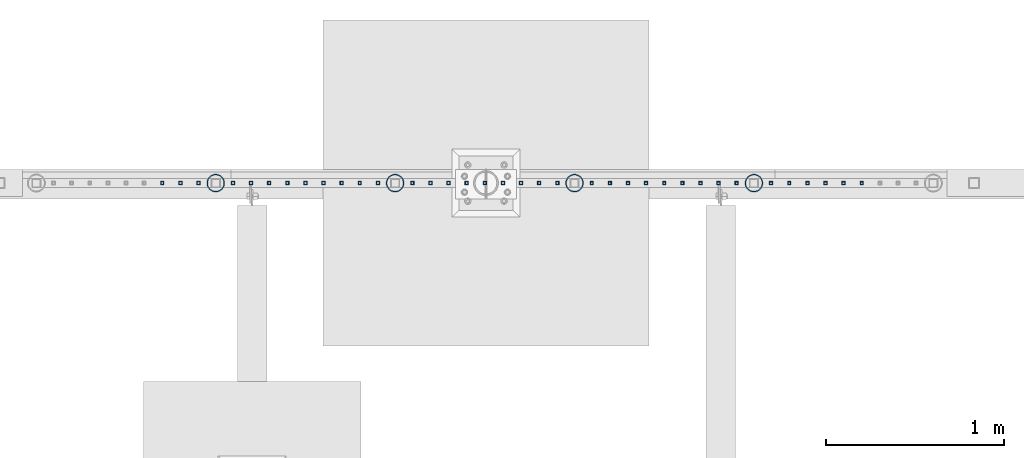
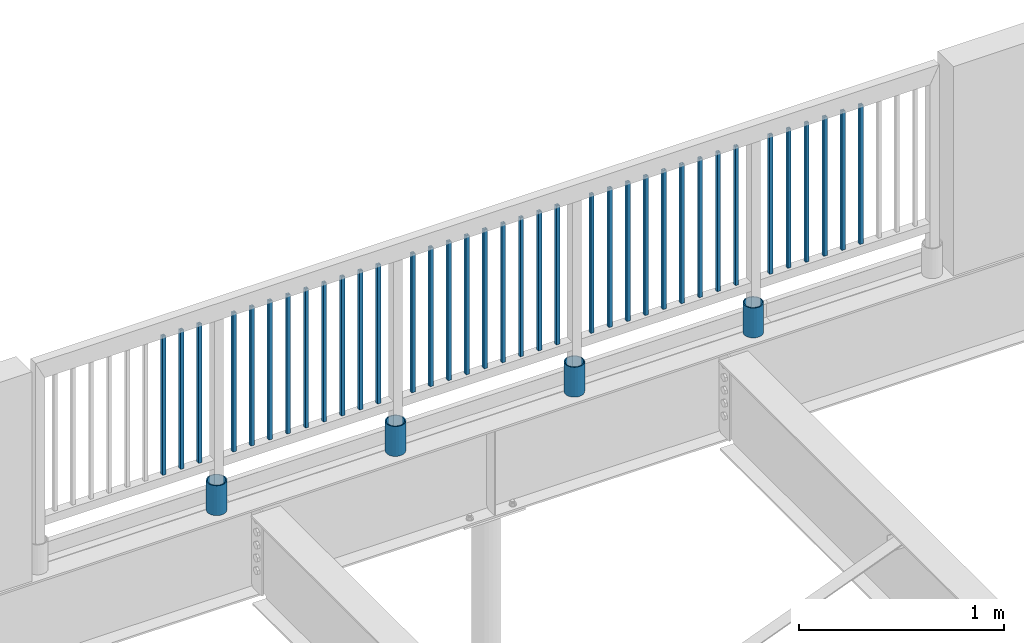
# One storey, part 234 of 975: 40 columns.
"""IFC2X3 building model written with IfcOpenShell, lengths in millimetres."""

from ifc_helpers import new_model, si_unit, frame, origin_with_axes, place, context, subcontext, project, spatial, faceted_brep, material, type_object, element, save


model = new_model("IFC2X3")

# Units and contexts
model_context = context("Model", 3, precision=1e-05, world=origin_with_axes())
body_context = subcontext(model_context, "Body", "Model", "MODEL_VIEW")
ifc_project = project(units=[si_unit("LENGTHUNIT", "METRE", prefix="MILLI"), si_unit("AREAUNIT", "SQUARE_METRE"), si_unit("VOLUMEUNIT", "CUBIC_METRE"), si_unit("MASSUNIT", "GRAM", prefix="KILO"), si_unit("TIMEUNIT", "SECOND"), si_unit("PLANEANGLEUNIT", "RADIAN"), si_unit("SOLIDANGLEUNIT", "STERADIAN"), si_unit("THERMODYNAMICTEMPERATUREUNIT", "DEGREE_CELSIUS"), si_unit("LUMINOUSINTENSITYUNIT", "LUMEN")], contexts=[model_context])

# Site, building, storey
site_placement = place(None, origin_with_axes())
site = spatial("IfcSite", under=ifc_project, at=site_placement, CompositionType="ELEMENT")
building_placement = place(site_placement, origin_with_axes())
building = spatial("IfcBuilding", under=site, at=building_placement, Name="Undefined", CompositionType="ELEMENT")
storey_placement = place(building_placement, origin_with_axes())
storey = spatial("IfcBuildingStorey", under=building, at=storey_placement, Name="Undefined", CompositionType="ELEMENT", Elevation=0.0)

# Columns
ifc_material_1 = material()
column_type_1 = type_object("IfcColumnType", Name="HSS3/4X3/4X.120_TUBES", PredefinedType="NOTDEFINED")
for number, where, z_axis, x_axis, name in (
    (1, (11647.8074787112, 29962.1756613159, 4254.49117560355), (1.0, 0.0, 0.0), (0.0, 0.0, 1.0), "PICKET"),
    (2, (11546.2074787112, 29962.1756613159, 4254.49117560355), (1.0, 0.0, 0.0), (0.0, 0.0, 1.0), "PICKET"),
    (3, (11444.6074787112, 29962.1756613159, 4254.49117560355), (1.0, 0.0, 0.0), (0.0, 0.0, 1.0), "PICKET"),
    (4, (11343.0074787112, 29962.1756613159, 4254.49117560355), (1.0, 0.0, 0.0), (0.0, 0.0, 1.0), "PICKET"),
    (5, (11241.4074787112, 29962.1756613159, 4254.49117560355), (1.0, 0.0, 0.0), (0.0, 0.0, 1.0), "PICKET"),
    (6, (11139.8074787112, 29962.1756613159, 4254.49117560355), (1.0, 0.0, 0.0), (0.0, 0.0, 1.0), "PICKET"),
    (7, (10946.7670968707, 29962.1851834192, 4254.49124442222), (1.0, 0.0, 0.0), (0.0, 0.0, 1.0), "PICKET"),
    (8, (10845.1670968707, 29962.1851834192, 4254.49124442222), (1.0, 0.0, 0.0), (0.0, 0.0, 1.0), "PICKET"),
    (9, (10743.5670968707, 29962.1851834192, 4254.49124442222), (1.0, 0.0, 0.0), (0.0, 0.0, 1.0), "PICKET"),
    (10, (10641.9670968707, 29962.1851834192, 4254.49124442222), (1.0, 0.0, 0.0), (0.0, 0.0, 1.0), "PICKET"),
    (11, (10540.3670968707, 29962.1851834192, 4254.49124442222), (1.0, 0.0, 0.0), (0.0, 0.0, 1.0), "PICKET"),
    (12, (10438.7670968707, 29962.1851834192, 4254.49124442222), (1.0, 0.0, 0.0), (0.0, 0.0, 1.0), "PICKET"),
    (13, (10337.1670968707, 29962.1851834192, 4254.49124442222), (1.0, 0.0, 0.0), (0.0, 0.0, 1.0), "PICKET"),
    (14, (10235.5670968707, 29962.1851834192, 4254.49124442222), (1.0, 0.0, 0.0), (0.0, 0.0, 1.0), "PICKET"),
    (15, (10133.9670968707, 29962.1851834192, 4254.49124442222), (1.0, 0.0, 0.0), (0.0, 0.0, 1.0), "PICKET"),
    (16, (9940.92734308254, 29962.3497637264, 4254.4913822527), (1.0, 0.0, 0.0), (0.0, 0.0, 1.0), "PICKET"),
    (17, (9839.32734308254, 29962.3497637264, 4254.4913822527), (1.0, 0.0, 0.0), (0.0, 0.0, 1.0), "PICKET"),
    (18, (9737.72734308254, 29962.3497637264, 4254.4913822527), (1.0, 0.0, 0.0), (0.0, 0.0, 1.0), "PICKET"),
    (19, (9636.12734308254, 29962.3497637264, 4254.4913822527), (1.0, 0.0, 0.0), (0.0, 0.0, 1.0), "PICKET"),
    (20, (9534.52734308254, 29962.3497637264, 4254.4913822527), (1.0, 0.0, 0.0), (0.0, 0.0, 1.0), "PICKET"),
    (21, (9432.92734308254, 29962.3497637264, 4254.4913822527), (1.0, 0.0, 0.0), (0.0, 0.0, 1.0), "PICKET"),
    (22, (9331.32734308254, 29962.3497637264, 4254.4913822527), (1.0, 0.0, 0.0), (0.0, 0.0, 1.0), "PICKET"),
    (23, (9229.72734308254, 29962.3497637264, 4254.4913822527), (1.0, 0.0, 0.0), (0.0, 0.0, 1.0), "PICKET"),
    (24, (9128.12734308254, 29962.3497637264, 4254.4913822527), (1.0, 0.0, 0.0), (0.0, 0.0, 1.0), "PICKET"),
    (25, (8935.08757637993, 29962.3592857994, 4254.49152008318), (1.0, 0.0, 0.0), (0.0, 0.0, 1.0), "PICKET"),
    (26, (8833.48757637993, 29962.3592857994, 4254.49152008318), (1.0, 0.0, 0.0), (0.0, 0.0, 1.0), "PICKET"),
    (27, (8731.88757637993, 29962.3592857994, 4254.49152008318), (1.0, 0.0, 0.0), (0.0, 0.0, 1.0), "PICKET"),
    (28, (8630.28757637993, 29962.3592857994, 4254.49152008318), (1.0, 0.0, 0.0), (0.0, 0.0, 1.0), "PICKET"),
    (29, (8528.68757637993, 29962.3592857994, 4254.49152008318), (1.0, 0.0, 0.0), (0.0, 0.0, 1.0), "PICKET"),
    (30, (8427.08757637993, 29962.3592857994, 4254.49152008318), (1.0, 0.0, 0.0), (0.0, 0.0, 1.0), "PICKET"),
    (31, (8325.48757637993, 29962.3592857994, 4254.49152008318), (1.0, 0.0, 0.0), (0.0, 0.0, 1.0), "PICKET"),
    (32, (8223.88757637994, 29962.3592857994, 4254.49152008318), (1.0, 0.0, 0.0), (0.0, 0.0, 1.0), "PICKET"),
    (33, (8122.28757637993, 29962.3592857994, 4254.49152008318), (1.0, 0.0, 0.0), (0.0, 0.0, 1.0), "PICKET"),
    (34, (7929.24783012341, 29962.3688078713, 4254.49165791356), (1.0, 0.0, 0.0), (0.0, 0.0, 1.0), "PICKET"),
    (35, (7827.6478301234, 29962.3688078713, 4254.49165791356), (1.0, 0.0, 0.0), (0.0, 0.0, 1.0), "PICKET"),
    (36, (7726.0478301234, 29962.3688078713, 4254.49165791356), (1.0, 0.0, 0.0), (0.0, 0.0, 1.0), "PICKET"),
):
    element("IfcColumn", number, at=place(storey_placement, frame(where, z_axis=z_axis, x_axis=x_axis)), inside=storey, type_object=column_type_1, material=ifc_material_1, Name=name, ObjectType="HSS3/4X3/4X.120_TUBES", context=body_context, shape_type="Brep", body=[
        faceted_brep([(0.0, 6.34999999998763, -6.34999999998763), (0.0, -6.35000000000582, -6.34999999998763), (825.49997943247, -6.35000000000582, -6.34999999998763), (825.49997943247, 6.34999999998763, -6.34999999998763), (0.0, -6.34999999998763, 6.34999999998763), (825.49997943247, -6.34999999998763, 6.34999999998763), (0.0, 6.35000000000946, 6.34999999998763), (825.49997943247, 6.35000000000946, 6.34999999998763), (0.0, 9.52499999997963, -9.52499999997963), (0.0, 9.52500000000873, 9.5249999999869), (825.49997943247, 9.52500000000873, 9.5249999999869), (825.49997943247, 9.52499999997963, -9.52499999997963), (0.0, -9.52499999997963, 9.52499999998327), (825.49997943247, -9.52499999997963, 9.52499999998327), (0.0, -9.52500000000873, -9.5249999999869), (825.49997943247, -9.52500000000873, -9.5249999999869)], [[[0, 1, 2, 3]], [[1, 4, 5, 2]], [[4, 6, 7, 5]], [[6, 0, 3, 7]], [[8, 9, 10, 11]], [[9, 12, 13, 10]], [[12, 14, 15, 13]], [[14, 8, 11, 15]], [[13, 15, 11, 10], [5, 7, 3, 2]], [[14, 12, 9, 8], [6, 4, 1, 0]]]),
    ])
ifc_material_2 = material(Name="STEEL/A53")
column_type_2 = type_object("IfcColumnType", Name="PIPE3-1/2STD", PredefinedType="NOTDEFINED")
column_1_placement = place(storey_placement, frame((11043.2862680762, 29962.0937719637, 3937.0), z_axis=(-0.707106781186601, 0.707106781186494, 2.36468622460961e-14), x_axis=(0.0, 0.0, 1.0)))
element("IfcColumn", 37, at=column_1_placement, inside=storey, type_object=column_type_2, material=ifc_material_2, ObjectType="PIPE3-1/2STD", context=body_context, shape_type="Brep", body=[
    faceted_brep([(0.0, -45.0595999999932, 1.45519152283669e-11), (0.0, -42.8542262016344, 13.924182159768), (177.8, -42.8542262016344, 13.924182159768), (177.8, -45.0595999999932, 1.45519152283669e-11), (0.0, -36.45398215971, 26.4853683542424), (177.8, -36.45398215971, 26.4853683542424), (0.0, -26.4853683541623, 36.45398215979), (177.8, -26.4853683541623, 36.45398215979), (0.0, -13.9241821596988, 42.8542262017108), (177.8, -13.9241821596988, 42.8542262017108), (0.0, 3.63797880709171e-11, 45.0596000000514), (177.8, 3.63797880709171e-11, 45.0596000000514), (0.0, 13.9241821597716, 42.8542262017036), (177.8, 13.9241821597716, 42.8542262017036), (0.0, 26.4853683542242, 36.4539821597718), (177.8, 26.4853683542242, 36.4539821597718), (0.0, 36.4539821597537, 26.4853683542206), (177.8, 36.4539821597537, 26.4853683542206), (0.0, 42.8542262016563, 13.9241821597425), (177.8, 42.8542262016563, 13.9241821597425), (0.0, 45.0595999999932, -1.09139364212751e-11), (177.8, 45.0595999999932, -1.09139364212751e-11), (0.0, 42.8542262016344, -13.9241821597643), (177.8, 42.8542262016344, -13.9241821597643), (0.0, 36.45398215971, -26.4853683542387), (177.8, 36.45398215971, -26.4853683542387), (0.0, 26.4853683541623, -36.4539821597864), (177.8, 26.4853683541623, -36.4539821597864), (0.0, 13.9241821596988, -42.8542262017072), (177.8, 13.9241821596988, -42.8542262017072), (0.0, -3.63797880709171e-11, -45.0596000000478), (177.8, -3.63797880709171e-11, -45.0596000000478), (0.0, -13.9241821597716, -42.8542262016963), (177.8, -13.9241821597716, -42.8542262016963), (0.0, -26.4853683542242, -36.4539821597682), (177.8, -26.4853683542242, -36.4539821597682), (0.0, -36.4539821597537, -26.4853683542169), (177.8, -36.4539821597537, -26.4853683542169), (0.0, -42.8542262016563, -13.9241821597352), (177.8, -42.8542262016563, -13.9241821597352), (0.0, -50.799999999992, 1.81898940354586e-11), (0.0, -48.3136710278013, -15.6980633142484), (177.8, -48.3136710278013, -15.6980633142484), (177.8, -50.799999999992, 1.81898940354586e-11), (0.0, -41.0980633142644, -29.8594908164741), (177.8, -41.0980633142644, -29.8594908164741), (0.0, -29.859490816485, -41.0980633142826), (177.8, -29.859490816485, -41.0980633142826), (0.0, -15.6980633142848, -48.313671027845), (177.8, -15.6980633142848, -48.313671027845), (0.0, -4.36557456851006e-11, -50.8000000000575), (177.8, -4.36557456851006e-11, -50.8000000000575), (0.0, 15.6980633142011, -48.3136710278523), (177.8, 15.6980633142011, -48.3136710278523), (0.0, 29.8594908164159, -41.0980633143045), (177.8, 29.8594908164159, -41.0980633143045), (0.0, 41.0980633142135, -29.8594908165032), (177.8, 41.0980633142135, -29.8594908165032), (0.0, 48.3136710277722, -15.6980633142775), (177.8, 48.3136710277722, -15.6980633142775), (0.0, 50.799999999992, -1.45519152283669e-11), (177.8, 50.799999999992, -1.45519152283669e-11), (0.0, 48.313671027794, 15.6980633142521), (177.8, 48.313671027794, 15.6980633142521), (0.0, 41.0980633142644, 29.8594908164814), (177.8, 41.0980633142644, 29.8594908164814), (0.0, 29.859490816485, 41.0980633142863), (177.8, 29.859490816485, 41.0980633142863), (0.0, 15.6980633142848, 48.3136710278486), (177.8, 15.6980633142848, 48.3136710278486), (0.0, 4.00177668780088e-11, 50.8000000000611), (177.8, 4.00177668780088e-11, 50.8000000000611), (0.0, -15.6980633142011, 48.3136710278559), (177.8, -15.6980633142011, 48.3136710278559), (0.0, -29.8594908164159, 41.0980633143081), (177.8, -29.8594908164159, 41.0980633143081), (0.0, -41.0980633142171, 29.8594908165069), (177.8, -41.0980633142171, 29.8594908165069), (0.0, -48.3136710277722, 15.6980633142812), (177.8, -48.3136710277722, 15.6980633142812)], [[[0, 1, 2, 3]], [[1, 4, 5, 2]], [[4, 6, 7, 5]], [[6, 8, 9, 7]], [[8, 10, 11, 9]], [[10, 12, 13, 11]], [[12, 14, 15, 13]], [[14, 16, 17, 15]], [[16, 18, 19, 17]], [[18, 20, 21, 19]], [[20, 22, 23, 21]], [[22, 24, 25, 23]], [[24, 26, 27, 25]], [[26, 28, 29, 27]], [[28, 30, 31, 29]], [[30, 32, 33, 31]], [[32, 34, 35, 33]], [[34, 36, 37, 35]], [[36, 38, 39, 37]], [[38, 0, 3, 39]], [[40, 41, 42, 43]], [[41, 44, 45, 42]], [[44, 46, 47, 45]], [[46, 48, 49, 47]], [[48, 50, 51, 49]], [[50, 52, 53, 51]], [[52, 54, 55, 53]], [[54, 56, 57, 55]], [[56, 58, 59, 57]], [[58, 60, 61, 59]], [[60, 62, 63, 61]], [[62, 64, 65, 63]], [[64, 66, 67, 65]], [[66, 68, 69, 67]], [[68, 70, 71, 69]], [[70, 72, 73, 71]], [[72, 74, 75, 73]], [[74, 76, 77, 75]], [[76, 78, 79, 77]], [[78, 40, 43, 79]], [[45, 47, 49, 51, 53, 55, 57, 59, 61, 63, 65, 67, 69, 71, 73, 75, 77, 79, 43, 42], [5, 7, 9, 11, 13, 15, 17, 19, 21, 23, 25, 27, 29, 31, 33, 35, 37, 39, 3, 2]], [[78, 76, 74, 72, 70, 68, 66, 64, 62, 60, 58, 56, 54, 52, 50, 48, 46, 44, 41, 40], [38, 36, 34, 32, 30, 28, 26, 24, 22, 20, 18, 16, 14, 12, 10, 8, 6, 4, 1, 0]]]),
])
column_2_placement = place(storey_placement, frame((10037.4465056714, 29962.1891578516, 3937.0), z_axis=(-0.707106781186601, 0.707106781186494, 2.36468622460961e-14), x_axis=(0.0, 0.0, 1.0)))
element("IfcColumn", 38, at=column_2_placement, inside=storey, type_object=column_type_2, material=ifc_material_2, ObjectType="PIPE3-1/2STD", context=body_context, shape_type="Brep", body=[
    faceted_brep([(0.0, -45.0595999999932, 1.45519152283669e-11), (0.0, -42.8542262016344, 13.924182159768), (177.8, -42.8542262016344, 13.924182159768), (177.8, -45.0595999999932, 1.45519152283669e-11), (0.0, -36.45398215971, 26.4853683542424), (177.8, -36.45398215971, 26.4853683542424), (0.0, -26.4853683541623, 36.45398215979), (177.8, -26.4853683541623, 36.45398215979), (0.0, -13.9241821596988, 42.8542262017108), (177.8, -13.9241821596988, 42.8542262017108), (0.0, 3.63797880709171e-11, 45.0596000000514), (177.8, 3.63797880709171e-11, 45.0596000000514), (0.0, 13.9241821597716, 42.8542262017036), (177.8, 13.9241821597716, 42.8542262017036), (0.0, 26.4853683542242, 36.4539821597718), (177.8, 26.4853683542242, 36.4539821597718), (0.0, 36.4539821597537, 26.4853683542206), (177.8, 36.4539821597537, 26.4853683542206), (0.0, 42.8542262016563, 13.9241821597425), (177.8, 42.8542262016563, 13.9241821597425), (0.0, 45.0595999999932, -1.09139364212751e-11), (177.8, 45.0595999999932, -1.09139364212751e-11), (0.0, 42.8542262016344, -13.9241821597643), (177.8, 42.8542262016344, -13.9241821597643), (0.0, 36.45398215971, -26.4853683542387), (177.8, 36.45398215971, -26.4853683542387), (0.0, 26.4853683541623, -36.4539821597864), (177.8, 26.4853683541623, -36.4539821597864), (0.0, 13.9241821596988, -42.8542262017072), (177.8, 13.9241821596988, -42.8542262017072), (0.0, -3.63797880709171e-11, -45.0596000000478), (177.8, -3.63797880709171e-11, -45.0596000000478), (0.0, -13.9241821597716, -42.8542262016963), (177.8, -13.9241821597716, -42.8542262016963), (0.0, -26.4853683542242, -36.4539821597682), (177.8, -26.4853683542242, -36.4539821597682), (0.0, -36.4539821597537, -26.4853683542169), (177.8, -36.4539821597537, -26.4853683542169), (0.0, -42.8542262016563, -13.9241821597352), (177.8, -42.8542262016563, -13.9241821597352), (0.0, -50.799999999992, 1.81898940354586e-11), (0.0, -48.3136710278013, -15.6980633142484), (177.8, -48.3136710278013, -15.6980633142484), (177.8, -50.799999999992, 1.81898940354586e-11), (0.0, -41.0980633142644, -29.8594908164741), (177.8, -41.0980633142644, -29.8594908164741), (0.0, -29.859490816485, -41.0980633142826), (177.8, -29.859490816485, -41.0980633142826), (0.0, -15.6980633142848, -48.313671027845), (177.8, -15.6980633142848, -48.313671027845), (0.0, -4.36557456851006e-11, -50.8000000000575), (177.8, -4.36557456851006e-11, -50.8000000000575), (0.0, 15.6980633142011, -48.3136710278523), (177.8, 15.6980633142011, -48.3136710278523), (0.0, 29.8594908164159, -41.0980633143045), (177.8, 29.8594908164159, -41.0980633143045), (0.0, 41.0980633142135, -29.8594908165032), (177.8, 41.0980633142135, -29.8594908165032), (0.0, 48.3136710277722, -15.6980633142775), (177.8, 48.3136710277722, -15.6980633142775), (0.0, 50.799999999992, -1.45519152283669e-11), (177.8, 50.799999999992, -1.45519152283669e-11), (0.0, 48.313671027794, 15.6980633142521), (177.8, 48.313671027794, 15.6980633142521), (0.0, 41.0980633142644, 29.8594908164814), (177.8, 41.0980633142644, 29.8594908164814), (0.0, 29.859490816485, 41.0980633142863), (177.8, 29.859490816485, 41.0980633142863), (0.0, 15.6980633142848, 48.3136710278486), (177.8, 15.6980633142848, 48.3136710278486), (0.0, 4.00177668780088e-11, 50.8000000000611), (177.8, 4.00177668780088e-11, 50.8000000000611), (0.0, -15.6980633142011, 48.3136710278559), (177.8, -15.6980633142011, 48.3136710278559), (0.0, -29.8594908164159, 41.0980633143081), (177.8, -29.8594908164159, 41.0980633143081), (0.0, -41.0980633142171, 29.8594908165069), (177.8, -41.0980633142171, 29.8594908165069), (0.0, -48.3136710277722, 15.6980633142812), (177.8, -48.3136710277722, 15.6980633142812)], [[[0, 1, 2, 3]], [[1, 4, 5, 2]], [[4, 6, 7, 5]], [[6, 8, 9, 7]], [[8, 10, 11, 9]], [[10, 12, 13, 11]], [[12, 14, 15, 13]], [[14, 16, 17, 15]], [[16, 18, 19, 17]], [[18, 20, 21, 19]], [[20, 22, 23, 21]], [[22, 24, 25, 23]], [[24, 26, 27, 25]], [[26, 28, 29, 27]], [[28, 30, 31, 29]], [[30, 32, 33, 31]], [[32, 34, 35, 33]], [[34, 36, 37, 35]], [[36, 38, 39, 37]], [[38, 0, 3, 39]], [[40, 41, 42, 43]], [[41, 44, 45, 42]], [[44, 46, 47, 45]], [[46, 48, 49, 47]], [[48, 50, 51, 49]], [[50, 52, 53, 51]], [[52, 54, 55, 53]], [[54, 56, 57, 55]], [[56, 58, 59, 57]], [[58, 60, 61, 59]], [[60, 62, 63, 61]], [[62, 64, 65, 63]], [[64, 66, 67, 65]], [[66, 68, 69, 67]], [[68, 70, 71, 69]], [[70, 72, 73, 71]], [[72, 74, 75, 73]], [[74, 76, 77, 75]], [[76, 78, 79, 77]], [[78, 40, 43, 79]], [[45, 47, 49, 51, 53, 55, 57, 59, 61, 63, 65, 67, 69, 71, 73, 75, 77, 79, 43, 42], [5, 7, 9, 11, 13, 15, 17, 19, 21, 23, 25, 27, 29, 31, 33, 35, 37, 39, 3, 2]], [[78, 76, 74, 72, 70, 68, 66, 64, 62, 60, 58, 56, 54, 52, 50, 48, 46, 44, 41, 40], [38, 36, 34, 32, 30, 28, 26, 24, 22, 20, 18, 16, 14, 12, 10, 8, 6, 4, 1, 0]]]),
])
column_3_placement = place(storey_placement, frame((9031.60674328245, 29962.2845441947, 3937.0), z_axis=(-0.707106781186601, 0.707106781186494, 2.36468622460961e-14), x_axis=(0.0, 0.0, 1.0)))
element("IfcColumn", 39, at=column_3_placement, inside=storey, type_object=column_type_2, material=ifc_material_2, ObjectType="PIPE3-1/2STD", context=body_context, shape_type="Brep", body=[
    faceted_brep([(0.0, -45.0595999999932, 1.45519152283669e-11), (0.0, -42.8542262016344, 13.924182159768), (177.8, -42.8542262016344, 13.924182159768), (177.8, -45.0595999999932, 1.45519152283669e-11), (0.0, -36.45398215971, 26.4853683542424), (177.8, -36.45398215971, 26.4853683542424), (0.0, -26.4853683541623, 36.45398215979), (177.8, -26.4853683541623, 36.45398215979), (0.0, -13.9241821596988, 42.8542262017108), (177.8, -13.9241821596988, 42.8542262017108), (0.0, 3.63797880709171e-11, 45.0596000000514), (177.8, 3.63797880709171e-11, 45.0596000000514), (0.0, 13.9241821597716, 42.8542262017036), (177.8, 13.9241821597716, 42.8542262017036), (0.0, 26.4853683542242, 36.4539821597718), (177.8, 26.4853683542242, 36.4539821597718), (0.0, 36.4539821597537, 26.4853683542206), (177.8, 36.4539821597537, 26.4853683542206), (0.0, 42.8542262016563, 13.9241821597425), (177.8, 42.8542262016563, 13.9241821597425), (0.0, 45.0595999999932, -1.09139364212751e-11), (177.8, 45.0595999999932, -1.09139364212751e-11), (0.0, 42.8542262016344, -13.9241821597643), (177.8, 42.8542262016344, -13.9241821597643), (0.0, 36.45398215971, -26.4853683542387), (177.8, 36.45398215971, -26.4853683542387), (0.0, 26.4853683541623, -36.4539821597864), (177.8, 26.4853683541623, -36.4539821597864), (0.0, 13.9241821596988, -42.8542262017072), (177.8, 13.9241821596988, -42.8542262017072), (0.0, -3.63797880709171e-11, -45.0596000000478), (177.8, -3.63797880709171e-11, -45.0596000000478), (0.0, -13.9241821597716, -42.8542262016963), (177.8, -13.9241821597716, -42.8542262016963), (0.0, -26.4853683542242, -36.4539821597682), (177.8, -26.4853683542242, -36.4539821597682), (0.0, -36.4539821597537, -26.4853683542169), (177.8, -36.4539821597537, -26.4853683542169), (0.0, -42.8542262016563, -13.9241821597352), (177.8, -42.8542262016563, -13.9241821597352), (0.0, -50.799999999992, 1.81898940354586e-11), (0.0, -48.3136710278013, -15.6980633142484), (177.8, -48.3136710278013, -15.6980633142484), (177.8, -50.799999999992, 1.81898940354586e-11), (0.0, -41.0980633142644, -29.8594908164741), (177.8, -41.0980633142644, -29.8594908164741), (0.0, -29.859490816485, -41.0980633142826), (177.8, -29.859490816485, -41.0980633142826), (0.0, -15.6980633142848, -48.313671027845), (177.8, -15.6980633142848, -48.313671027845), (0.0, -4.36557456851006e-11, -50.8000000000575), (177.8, -4.36557456851006e-11, -50.8000000000575), (0.0, 15.6980633142011, -48.3136710278523), (177.8, 15.6980633142011, -48.3136710278523), (0.0, 29.8594908164159, -41.0980633143045), (177.8, 29.8594908164159, -41.0980633143045), (0.0, 41.0980633142135, -29.8594908165032), (177.8, 41.0980633142135, -29.8594908165032), (0.0, 48.3136710277722, -15.6980633142775), (177.8, 48.3136710277722, -15.6980633142775), (0.0, 50.799999999992, -1.45519152283669e-11), (177.8, 50.799999999992, -1.45519152283669e-11), (0.0, 48.313671027794, 15.6980633142521), (177.8, 48.313671027794, 15.6980633142521), (0.0, 41.0980633142644, 29.8594908164814), (177.8, 41.0980633142644, 29.8594908164814), (0.0, 29.859490816485, 41.0980633142863), (177.8, 29.859490816485, 41.0980633142863), (0.0, 15.6980633142848, 48.3136710278486), (177.8, 15.6980633142848, 48.3136710278486), (0.0, 4.00177668780088e-11, 50.8000000000611), (177.8, 4.00177668780088e-11, 50.8000000000611), (0.0, -15.6980633142011, 48.3136710278559), (177.8, -15.6980633142011, 48.3136710278559), (0.0, -29.8594908164159, 41.0980633143081), (177.8, -29.8594908164159, 41.0980633143081), (0.0, -41.0980633142171, 29.8594908165069), (177.8, -41.0980633142171, 29.8594908165069), (0.0, -48.3136710277722, 15.6980633142812), (177.8, -48.3136710277722, 15.6980633142812)], [[[0, 1, 2, 3]], [[1, 4, 5, 2]], [[4, 6, 7, 5]], [[6, 8, 9, 7]], [[8, 10, 11, 9]], [[10, 12, 13, 11]], [[12, 14, 15, 13]], [[14, 16, 17, 15]], [[16, 18, 19, 17]], [[18, 20, 21, 19]], [[20, 22, 23, 21]], [[22, 24, 25, 23]], [[24, 26, 27, 25]], [[26, 28, 29, 27]], [[28, 30, 31, 29]], [[30, 32, 33, 31]], [[32, 34, 35, 33]], [[34, 36, 37, 35]], [[36, 38, 39, 37]], [[38, 0, 3, 39]], [[40, 41, 42, 43]], [[41, 44, 45, 42]], [[44, 46, 47, 45]], [[46, 48, 49, 47]], [[48, 50, 51, 49]], [[50, 52, 53, 51]], [[52, 54, 55, 53]], [[54, 56, 57, 55]], [[56, 58, 59, 57]], [[58, 60, 61, 59]], [[60, 62, 63, 61]], [[62, 64, 65, 63]], [[64, 66, 67, 65]], [[66, 68, 69, 67]], [[68, 70, 71, 69]], [[70, 72, 73, 71]], [[72, 74, 75, 73]], [[74, 76, 77, 75]], [[76, 78, 79, 77]], [[78, 40, 43, 79]], [[45, 47, 49, 51, 53, 55, 57, 59, 61, 63, 65, 67, 69, 71, 73, 75, 77, 79, 43, 42], [5, 7, 9, 11, 13, 15, 17, 19, 21, 23, 25, 27, 29, 31, 33, 35, 37, 39, 3, 2]], [[78, 76, 74, 72, 70, 68, 66, 64, 62, 60, 58, 56, 54, 52, 50, 48, 46, 44, 41, 40], [38, 36, 34, 32, 30, 28, 26, 24, 22, 20, 18, 16, 14, 12, 10, 8, 6, 4, 1, 0]]]),
])
column_4_placement = place(storey_placement, frame((8025.76698089322, 29962.3799309991, 3937.0), z_axis=(-0.707106781186601, 0.707106781186494, 2.36468622460961e-14), x_axis=(0.0, 0.0, 1.0)))
element("IfcColumn", 40, at=column_4_placement, inside=storey, type_object=column_type_2, material=ifc_material_2, ObjectType="PIPE3-1/2STD", context=body_context, shape_type="Brep", body=[
    faceted_brep([(0.0, -45.0595999999932, 1.45519152283669e-11), (0.0, -42.8542262016344, 13.924182159768), (177.8, -42.8542262016344, 13.924182159768), (177.8, -45.0595999999932, 1.45519152283669e-11), (0.0, -36.45398215971, 26.4853683542424), (177.8, -36.45398215971, 26.4853683542424), (0.0, -26.4853683541623, 36.45398215979), (177.8, -26.4853683541623, 36.45398215979), (0.0, -13.9241821596988, 42.8542262017108), (177.8, -13.9241821596988, 42.8542262017108), (0.0, 3.63797880709171e-11, 45.0596000000514), (177.8, 3.63797880709171e-11, 45.0596000000514), (0.0, 13.9241821597716, 42.8542262017036), (177.8, 13.9241821597716, 42.8542262017036), (0.0, 26.4853683542242, 36.4539821597718), (177.8, 26.4853683542242, 36.4539821597718), (0.0, 36.4539821597537, 26.4853683542206), (177.8, 36.4539821597537, 26.4853683542206), (0.0, 42.8542262016563, 13.9241821597425), (177.8, 42.8542262016563, 13.9241821597425), (0.0, 45.0595999999932, -1.09139364212751e-11), (177.8, 45.0595999999932, -1.09139364212751e-11), (0.0, 42.8542262016344, -13.9241821597643), (177.8, 42.8542262016344, -13.9241821597643), (0.0, 36.45398215971, -26.4853683542387), (177.8, 36.45398215971, -26.4853683542387), (0.0, 26.4853683541623, -36.4539821597864), (177.8, 26.4853683541623, -36.4539821597864), (0.0, 13.9241821596988, -42.8542262017072), (177.8, 13.9241821596988, -42.8542262017072), (0.0, -3.63797880709171e-11, -45.0596000000478), (177.8, -3.63797880709171e-11, -45.0596000000478), (0.0, -13.9241821597716, -42.8542262016963), (177.8, -13.9241821597716, -42.8542262016963), (0.0, -26.4853683542242, -36.4539821597682), (177.8, -26.4853683542242, -36.4539821597682), (0.0, -36.4539821597537, -26.4853683542169), (177.8, -36.4539821597537, -26.4853683542169), (0.0, -42.8542262016563, -13.9241821597352), (177.8, -42.8542262016563, -13.9241821597352), (0.0, -50.799999999992, 1.81898940354586e-11), (0.0, -48.3136710278013, -15.6980633142484), (177.8, -48.3136710278013, -15.6980633142484), (177.8, -50.799999999992, 1.81898940354586e-11), (0.0, -41.0980633142644, -29.8594908164741), (177.8, -41.0980633142644, -29.8594908164741), (0.0, -29.859490816485, -41.0980633142826), (177.8, -29.859490816485, -41.0980633142826), (0.0, -15.6980633142848, -48.313671027845), (177.8, -15.6980633142848, -48.313671027845), (0.0, -4.36557456851006e-11, -50.8000000000575), (177.8, -4.36557456851006e-11, -50.8000000000575), (0.0, 15.6980633142011, -48.3136710278523), (177.8, 15.6980633142011, -48.3136710278523), (0.0, 29.8594908164159, -41.0980633143045), (177.8, 29.8594908164159, -41.0980633143045), (0.0, 41.0980633142135, -29.8594908165032), (177.8, 41.0980633142135, -29.8594908165032), (0.0, 48.3136710277722, -15.6980633142775), (177.8, 48.3136710277722, -15.6980633142775), (0.0, 50.799999999992, -1.45519152283669e-11), (177.8, 50.799999999992, -1.45519152283669e-11), (0.0, 48.313671027794, 15.6980633142521), (177.8, 48.313671027794, 15.6980633142521), (0.0, 41.0980633142644, 29.8594908164814), (177.8, 41.0980633142644, 29.8594908164814), (0.0, 29.859490816485, 41.0980633142863), (177.8, 29.859490816485, 41.0980633142863), (0.0, 15.6980633142848, 48.3136710278486), (177.8, 15.6980633142848, 48.3136710278486), (0.0, 4.00177668780088e-11, 50.8000000000611), (177.8, 4.00177668780088e-11, 50.8000000000611), (0.0, -15.6980633142011, 48.3136710278559), (177.8, -15.6980633142011, 48.3136710278559), (0.0, -29.8594908164159, 41.0980633143081), (177.8, -29.8594908164159, 41.0980633143081), (0.0, -41.0980633142171, 29.8594908165069), (177.8, -41.0980633142171, 29.8594908165069), (0.0, -48.3136710277722, 15.6980633142812), (177.8, -48.3136710277722, 15.6980633142812)], [[[0, 1, 2, 3]], [[1, 4, 5, 2]], [[4, 6, 7, 5]], [[6, 8, 9, 7]], [[8, 10, 11, 9]], [[10, 12, 13, 11]], [[12, 14, 15, 13]], [[14, 16, 17, 15]], [[16, 18, 19, 17]], [[18, 20, 21, 19]], [[20, 22, 23, 21]], [[22, 24, 25, 23]], [[24, 26, 27, 25]], [[26, 28, 29, 27]], [[28, 30, 31, 29]], [[30, 32, 33, 31]], [[32, 34, 35, 33]], [[34, 36, 37, 35]], [[36, 38, 39, 37]], [[38, 0, 3, 39]], [[40, 41, 42, 43]], [[41, 44, 45, 42]], [[44, 46, 47, 45]], [[46, 48, 49, 47]], [[48, 50, 51, 49]], [[50, 52, 53, 51]], [[52, 54, 55, 53]], [[54, 56, 57, 55]], [[56, 58, 59, 57]], [[58, 60, 61, 59]], [[60, 62, 63, 61]], [[62, 64, 65, 63]], [[64, 66, 67, 65]], [[66, 68, 69, 67]], [[68, 70, 71, 69]], [[70, 72, 73, 71]], [[72, 74, 75, 73]], [[74, 76, 77, 75]], [[76, 78, 79, 77]], [[78, 40, 43, 79]], [[45, 47, 49, 51, 53, 55, 57, 59, 61, 63, 65, 67, 69, 71, 73, 75, 77, 79, 43, 42], [5, 7, 9, 11, 13, 15, 17, 19, 21, 23, 25, 27, 29, 31, 33, 35, 37, 39, 3, 2]], [[78, 76, 74, 72, 70, 68, 66, 64, 62, 60, 58, 56, 54, 52, 50, 48, 46, 44, 41, 40], [38, 36, 34, 32, 30, 28, 26, 24, 22, 20, 18, 16, 14, 12, 10, 8, 6, 4, 1, 0]]]),
])

save(model, "model.ifc")
